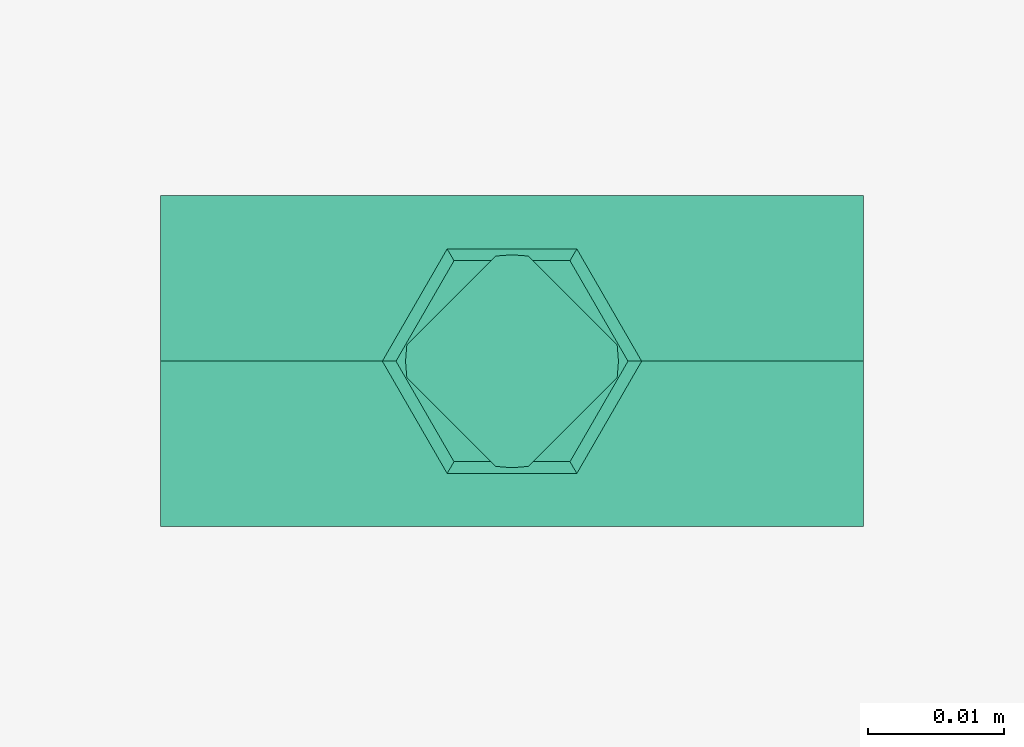
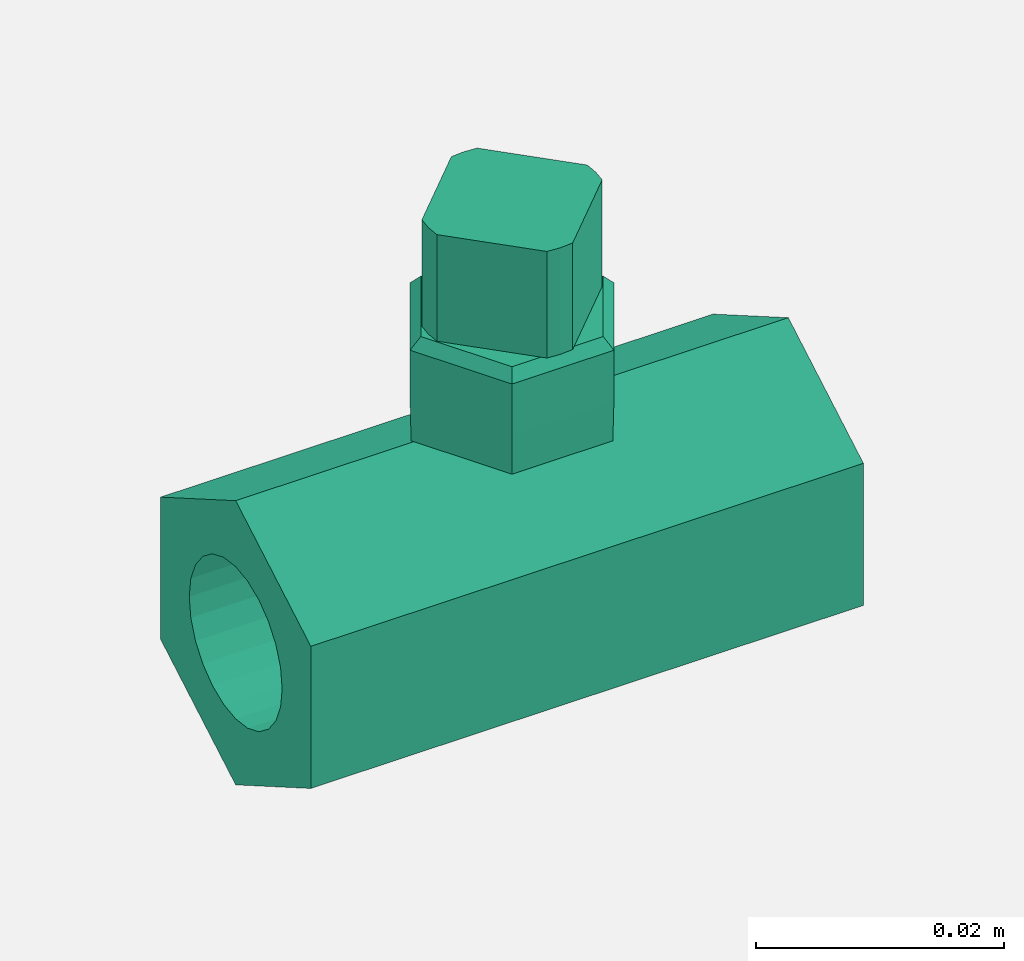
# One storey, part 2 of 2: 1 flow terminal.
"""IFC2X3 building model written with IfcOpenShell, lengths in metres."""

from ifc_helpers import new_model, entity, si_unit, converted_unit, derived_unit, direction, frame, origin, place, context, subcontext, project, spatial, faceted_brep, source, transform, mapped, material, element, save


model = new_model("IFC2X3")

# Units and contexts
model_context = context("Model", 3, precision=1e-05, world=origin(), true_north=direction((6.12303176911189e-17, 1.0)))
body_context = subcontext(model_context, "Body", "Model", "MODEL_VIEW")
ifc_project = project(units=[si_unit("LENGTHUNIT", "METRE"), si_unit("AREAUNIT", "SQUARE_METRE"), si_unit("VOLUMEUNIT", "CUBIC_METRE"), converted_unit("PLANEANGLEUNIT", "DEGREE", entity("IfcRatioMeasure", 0.0174532925199433), si_unit("PLANEANGLEUNIT", "RADIAN"), dimensions=[0, 0, 0, 0, 0, 0, 0]), si_unit("MASSUNIT", "GRAM", prefix="KILO"), derived_unit("MASSDENSITYUNIT", [(si_unit("MASSUNIT", "GRAM", prefix="KILO"), 1), (si_unit("LENGTHUNIT", "METRE"), -3)]), si_unit("TIMEUNIT", "SECOND"), si_unit("FREQUENCYUNIT", "HERTZ"), si_unit("THERMODYNAMICTEMPERATUREUNIT", "DEGREE_CELSIUS"), derived_unit("THERMALTRANSMITTANCEUNIT", [(si_unit("MASSUNIT", "GRAM", prefix="KILO"), 1), (si_unit("THERMODYNAMICTEMPERATUREUNIT", "KELVIN"), -1), (si_unit("TIMEUNIT", "SECOND"), -3)]), derived_unit("VOLUMETRICFLOWRATEUNIT", [(si_unit("LENGTHUNIT", "METRE"), 3), (si_unit("TIMEUNIT", "SECOND"), -1)]), si_unit("ELECTRICCURRENTUNIT", "AMPERE"), si_unit("ELECTRICVOLTAGEUNIT", "VOLT"), si_unit("POWERUNIT", "WATT"), si_unit("FORCEUNIT", "NEWTON", prefix="KILO"), si_unit("ILLUMINANCEUNIT", "LUX"), si_unit("LUMINOUSFLUXUNIT", "LUMEN"), si_unit("LUMINOUSINTENSITYUNIT", "CANDELA"), derived_unit("USERDEFINED", [(si_unit("MASSUNIT", "GRAM", prefix="KILO"), -1), (si_unit("LENGTHUNIT", "METRE"), -2), (si_unit("TIMEUNIT", "SECOND"), 3), (si_unit("LUMINOUSFLUXUNIT", "LUMEN"), 1)]), derived_unit("LINEARVELOCITYUNIT", [(si_unit("LENGTHUNIT", "METRE"), 1), (si_unit("TIMEUNIT", "SECOND"), -1)]), si_unit("PRESSUREUNIT", "PASCAL"), derived_unit("USERDEFINED", [(si_unit("LENGTHUNIT", "METRE"), -2), (si_unit("MASSUNIT", "GRAM", prefix="KILO"), 1), (si_unit("TIMEUNIT", "SECOND"), -2)])], contexts=[model_context])

# Site, building, storey
site_placement = place(None, origin())
site = spatial("IfcSite", under=ifc_project, at=site_placement, CompositionType="ELEMENT")
building_placement = place(site_placement, origin())
building = spatial("IfcBuilding", under=site, at=building_placement, CompositionType="ELEMENT")
storey_placement = place(building_placement, origin())
storey = spatial("IfcBuildingStorey", under=building, at=storey_placement, Name="0 - Piano Terra", CompositionType="ELEMENT", Elevation=0.0)

# Flow terminal
ifc_material = material(Name="di")
shared_shape = source(origin(), body_context, "Body", "Brep", [
    faceted_brep([(0.00120285026843495, 0.00770265547619037, 0.0486326952382922), (0.0, 0.00779596025503844, 0.0486326952382922), (-0.00120285026843501, 0.00770265547619036, 0.0486326952382922), (-0.00770669522115193, 0.00119881052347343, 0.0486326952382922), (-0.0078, -4.03974496152365e-06, 0.0486326952382922), (-0.00770669522115196, -0.0012068900133965, 0.0486326952382922), (-0.00120285026843499, -0.00771073496611347, 0.0486326952382922), (0.0, -0.00780403974496155, 0.0486326952382922), (0.00120285026843493, -0.00771073496611348, 0.0486326952382922), (0.00770669522115189, -0.00120689001339652, 0.0486326952382922), (0.00779999999999997, -4.03974496154639e-06, 0.0486326952382922), (0.00770669522115189, 0.00119881052347343, 0.0486326952382922), (0.0077066952211519, -0.00120689001339647, 0.0381326944485307), (0.00120285026843493, -0.00771073496611348, 0.0381326944485307), (0.0, -0.00780403974496155, 0.0381326944485307), (-0.00120285026843494, -0.00771073496611348, 0.0381326944485307), (-0.00770669522115193, -0.00120689001339648, 0.0381326944485307), (-0.0078, -4.03974496152365e-06, 0.0381326944485307), (-0.00770669522115193, 0.00119881052347338, 0.0381326944485307), (-0.00120285026843501, 0.00770265547619036, 0.0381326944485307), (0.0, 0.00779596025503844, 0.0381326944485307), (0.00120285026843491, 0.00770265547619038, 0.0381326944485307), (0.00770669522115189, 0.00119881052347343, 0.0381326944485307), (0.00779999999999997, -4.03974496154639e-06, 0.0381326944485307)], [[[0, 1, 2, 3, 4, 5, 6, 7, 8, 9, 10, 11]], [[12, 13, 14, 15, 16, 17, 18, 19, 20, 21, 22, 23]], [[3, 2, 19, 18]], [[3, 18, 17, 4]], [[17, 16, 5, 4]], [[6, 5, 16, 15]], [[6, 15, 14, 7]], [[14, 13, 8, 7]], [[9, 8, 13, 12]], [[9, 12, 23, 10]], [[23, 22, 11, 10]], [[0, 11, 22, 21]], [[0, 21, 20, 1]], [[20, 19, 2, 1]]]),
    faceted_brep([(-0.00425000059604643, 0.00736121696455046, 0.0381326944485307), (-0.00850000119209289, 0.0, 0.0381326944485307), (0.0, 0.0, 0.0381326944485307), (0.00425000059604645, 0.00736121696455045, 0.0381326944485307), (-0.00425000059604648, -0.00736121696455044, 0.0381326944485307), (0.0042500005960464, -0.00736121696455048, 0.0381326944485307), (0.00850000119209289, 0.0, 0.0381326944485307), (0.0, 0.0, 0.028175), (-0.00939737323296503, 0.0, 0.0281750000000001), (-0.00469868661648251, 0.00813836394859161, 0.028175), (0.00469868661648249, 0.00813836394859159, 0.028175), (0.00939737323296499, 0.0, 0.028175), (-0.00469868661648256, -0.00813836394859158, 0.028175), (0.00469868661648244, -0.00813836394859162, 0.028175), (0.00475000021234156, 0.00822724170373854, 0.0321326953277006), (0.00950000042468312, 0.0, 0.0321326953277006), (-0.00475000021234156, 0.00822724170373856, 0.0321326953277007), (-0.00950000042468315, 0.0, 0.0321326953277007), (-0.00475000021234161, -0.00822724170373853, 0.0321326953277007), (0.00475000021234151, -0.00822724170373857, 0.0321326953277006), (0.00475000021234155, 0.0082272417037385, 0.0371326961472631), (0.00950000042468308, 0.0, 0.0371326961472631), (-0.00475000021234153, 0.00822724170373852, 0.0371326961472631), (-0.00950000042468309, 0.0, 0.0371326961472631), (-0.00475000021234158, -0.00822724170373849, 0.0371326961472631), (0.00475000021234149, -0.00822724170373853, 0.0371326961472631)], [[[0, 1, 2]], [[2, 3, 0]], [[1, 4, 2]], [[5, 2, 4]], [[2, 5, 6]], [[2, 6, 3]], [[7, 8, 9]], [[9, 10, 7]], [[10, 11, 7]], [[7, 12, 8]], [[11, 13, 7]], [[12, 7, 13]], [[11, 10, 14, 15]], [[10, 9, 16, 14]], [[9, 8, 17, 16]], [[8, 12, 18, 17]], [[12, 13, 19, 18]], [[13, 11, 15, 19]], [[15, 14, 20, 21]], [[14, 16, 22, 20]], [[16, 17, 23, 22]], [[17, 18, 24, 23]], [[18, 19, 25, 24]], [[19, 15, 21, 25]], [[21, 20, 3, 6]], [[20, 22, 0, 3]], [[22, 23, 1, 0]], [[23, 24, 4, 1]], [[24, 25, 5, 4]], [[25, 21, 6, 5]]]),
    faceted_brep([(0.02575, -0.00375000000000001, 0.0204951905283833), (0.02575, 0.0, 0.028), (0.02575, -0.0121243556529821, 0.0210000000000001), (0.02575, -0.00194114283826891, 0.021244443697168), (0.02575, -0.00530330085889911, 0.0193033008588991), (0.02575, 0.0, 0.0215), (0.02575, 0.00194114283826889, 0.021244443697168), (0.02575, 0.00374999999999999, 0.0204951905283833), (0.02575, 0.0121243556529822, 0.0209999999999998), (0.02575, 0.00530330085889909, 0.0193033008588991), (0.02575, 0.00649519052838328, 0.01775), (0.02575, 0.00724444369716801, 0.0159411428382689), (0.02575, 0.0075, 0.014), (0.02575, 0.0121243556529821, 0.00699999999999986), (0.02575, 0.00724444369716802, 0.0120588571617311), (0.02575, 0.0064951905283833, 0.01025), (0.02575, 0.00530330085889913, 0.0086966991411009), (0.02575, 0.00375000000000003, 0.00750480947161671), (0.02575, 0.0, 0.0), (0.02575, 0.00194114283826894, 0.00675555630283198), (0.02575, 0.0, 0.00649999999999998), (0.02575, -0.00194114283826887, 0.00675555630283196), (0.02575, -0.00374999999999997, 0.00750480947161667), (0.02575, -0.0121243556529822, 0.00700000000000008), (0.02575, -0.00530330085889908, 0.00869669914110085), (0.02575, -0.00649519052838327, 0.0102499999999999), (0.02575, -0.007244443697168, 0.012058857161731), (0.02575, -0.0075, 0.014), (0.02575, -0.00724444369716801, 0.0159411428382689), (0.02575, -0.00649519052838329, 0.01775), (-0.02575, -0.00374999999999997, 0.00750480947161667), (-0.02575, 0.0, 0.0), (-0.02575, -0.0121243556529822, 0.00700000000000008), (-0.02575, -0.00194114283826887, 0.00675555630283196), (-0.02575, -0.00530330085889908, 0.00869669914110085), (-0.02575, 0.0, 0.00649999999999998), (-0.02575, 0.00194114283826894, 0.00675555630283198), (-0.02575, 0.00375000000000003, 0.00750480947161671), (-0.02575, 0.0121243556529821, 0.00699999999999986), (-0.02575, 0.00530330085889913, 0.0086966991411009), (-0.02575, 0.0064951905283833, 0.01025), (-0.02575, 0.00724444369716802, 0.0120588571617311), (-0.02575, 0.0075, 0.014), (-0.02575, 0.0121243556529822, 0.0209999999999998), (-0.02575, 0.00724444369716801, 0.0159411428382689), (-0.02575, 0.00649519052838328, 0.01775), (-0.02575, 0.00530330085889909, 0.0193033008588991), (-0.02575, 0.00374999999999999, 0.0204951905283833), (-0.02575, 0.0, 0.028), (-0.02575, 0.00194114283826889, 0.021244443697168), (-0.02575, 0.0, 0.0215), (-0.02575, -0.00194114283826891, 0.021244443697168), (-0.02575, -0.00375000000000001, 0.0204951905283833), (-0.02575, -0.0121243556529821, 0.0210000000000001), (-0.02575, -0.00530330085889911, 0.0193033008588991), (-0.02575, -0.00649519052838329, 0.01775), (-0.02575, -0.00724444369716801, 0.0159411428382689), (-0.02575, -0.0075, 0.0139999999999999), (-0.02575, -0.007244443697168, 0.012058857161731), (-0.02575, -0.00649519052838327, 0.0102499999999999)], [[[0, 1, 2]], [[1, 0, 3]], [[0, 2, 4]], [[5, 1, 3]], [[1, 5, 6]], [[7, 1, 6]], [[1, 7, 8]], [[7, 9, 8]], [[9, 10, 8]], [[10, 11, 8]], [[8, 11, 12]], [[12, 13, 8]], [[12, 14, 13]], [[15, 13, 14]], [[15, 16, 13]], [[17, 13, 16]], [[13, 17, 18]], [[19, 18, 17]], [[18, 19, 20]], [[18, 20, 21]], [[21, 22, 18]], [[18, 22, 23]], [[23, 22, 24]], [[24, 25, 23]], [[25, 26, 23]], [[26, 27, 23]], [[27, 28, 2]], [[2, 23, 27]], [[28, 29, 2]], [[29, 4, 2]], [[30, 31, 32]], [[31, 30, 33]], [[30, 32, 34]], [[35, 31, 33]], [[31, 35, 36]], [[37, 31, 36]], [[31, 37, 38]], [[37, 39, 38]], [[39, 40, 38]], [[40, 41, 38]], [[38, 41, 42]], [[42, 43, 38]], [[42, 44, 43]], [[45, 43, 44]], [[45, 46, 43]], [[47, 43, 46]], [[43, 47, 48]], [[49, 48, 47]], [[48, 49, 50]], [[48, 50, 51]], [[51, 52, 48]], [[48, 52, 53]], [[53, 52, 54]], [[54, 55, 53]], [[55, 56, 53]], [[56, 57, 53]], [[57, 58, 32]], [[32, 53, 57]], [[58, 59, 32]], [[59, 34, 32]], [[23, 2, 53, 32]], [[18, 23, 32, 31]], [[13, 18, 31, 38]], [[8, 13, 38, 43]], [[1, 8, 43, 48]], [[2, 1, 48, 53]], [[12, 42, 41, 14]], [[14, 41, 40, 15]], [[17, 16, 39, 37]], [[39, 16, 15, 40]], [[19, 17, 37, 36]], [[19, 36, 35, 20]], [[20, 35, 33, 21]], [[21, 33, 30, 22]], [[25, 24, 34, 59]], [[34, 24, 22, 30]], [[26, 25, 59, 58]], [[26, 58, 57, 27]], [[27, 57, 56, 28]], [[28, 56, 55, 29]], [[0, 4, 54, 52]], [[54, 4, 29, 55]], [[3, 0, 52, 51]], [[3, 51, 50, 5]], [[5, 50, 49, 6]], [[6, 49, 47, 7]], [[9, 46, 45, 10]], [[7, 47, 46, 9]], [[10, 45, 44, 11]], [[11, 44, 42, 12]]]),
    faceted_brep([(0.00120285026843495, 0.00770265547619037, 0.0486326952382922), (0.0, 0.00779596025503844, 0.0486326952382922), (-0.00120285026843501, 0.00770265547619036, 0.0486326952382922), (-0.00770669522115193, 0.00119881052347343, 0.0486326952382922), (-0.0078, -4.03974496152365e-06, 0.0486326952382922), (-0.00770669522115196, -0.0012068900133965, 0.0486326952382922), (-0.00120285026843499, -0.00771073496611347, 0.0486326952382922), (0.0, -0.00780403974496155, 0.0486326952382922), (0.00120285026843493, -0.00771073496611348, 0.0486326952382922), (0.00770669522115189, -0.00120689001339652, 0.0486326952382922), (0.00779999999999997, -4.03974496154639e-06, 0.0486326952382922), (0.00770669522115189, 0.00119881052347343, 0.0486326952382922), (0.0077066952211519, -0.00120689001339647, 0.0381326944485307), (0.00120285026843493, -0.00771073496611348, 0.0381326944485307), (0.0, -0.00780403974496155, 0.0381326944485307), (-0.00120285026843494, -0.00771073496611348, 0.0381326944485307), (-0.00770669522115193, -0.00120689001339648, 0.0381326944485307), (-0.0078, -4.03974496152365e-06, 0.0381326944485307), (-0.00770669522115193, 0.00119881052347338, 0.0381326944485307), (-0.00120285026843501, 0.00770265547619036, 0.0381326944485307), (0.0, 0.00779596025503844, 0.0381326944485307), (0.00120285026843491, 0.00770265547619038, 0.0381326944485307), (0.00770669522115189, 0.00119881052347343, 0.0381326944485307), (0.00779999999999997, -4.03974496154639e-06, 0.0381326944485307)], [[[0, 1, 2, 3, 4, 5, 6, 7, 8, 9, 10, 11]], [[12, 13, 14, 15, 16, 17, 18, 19, 20, 21, 22, 23]], [[3, 2, 19, 18]], [[3, 18, 17, 4]], [[17, 16, 5, 4]], [[6, 5, 16, 15]], [[6, 15, 14, 7]], [[14, 13, 8, 7]], [[9, 8, 13, 12]], [[9, 12, 23, 10]], [[23, 22, 11, 10]], [[0, 11, 22, 21]], [[0, 21, 20, 1]], [[20, 19, 2, 1]]]),
    faceted_brep([(-0.00425000059604643, 0.00736121696455046, 0.0381326944485307), (-0.00850000119209289, 0.0, 0.0381326944485307), (0.0, 0.0, 0.0381326944485307), (0.00425000059604645, 0.00736121696455045, 0.0381326944485307), (-0.00425000059604648, -0.00736121696455044, 0.0381326944485307), (0.0042500005960464, -0.00736121696455048, 0.0381326944485307), (0.00850000119209289, 0.0, 0.0381326944485307), (0.0, 0.0, 0.028175), (-0.00939737323296503, 0.0, 0.0281750000000001), (-0.00469868661648251, 0.00813836394859161, 0.028175), (0.00469868661648249, 0.00813836394859159, 0.028175), (0.00939737323296499, 0.0, 0.028175), (-0.00469868661648256, -0.00813836394859158, 0.028175), (0.00469868661648244, -0.00813836394859162, 0.028175), (0.00475000021234156, 0.00822724170373854, 0.0321326953277006), (0.00950000042468312, 0.0, 0.0321326953277006), (-0.00475000021234156, 0.00822724170373856, 0.0321326953277007), (-0.00950000042468315, 0.0, 0.0321326953277007), (-0.00475000021234161, -0.00822724170373853, 0.0321326953277007), (0.00475000021234151, -0.00822724170373857, 0.0321326953277006), (0.00475000021234155, 0.0082272417037385, 0.0371326961472631), (0.00950000042468308, 0.0, 0.0371326961472631), (-0.00475000021234153, 0.00822724170373852, 0.0371326961472631), (-0.00950000042468309, 0.0, 0.0371326961472631), (-0.00475000021234158, -0.00822724170373849, 0.0371326961472631), (0.00475000021234149, -0.00822724170373853, 0.0371326961472631)], [[[0, 1, 2]], [[2, 3, 0]], [[1, 4, 2]], [[5, 2, 4]], [[2, 5, 6]], [[2, 6, 3]], [[7, 8, 9]], [[9, 10, 7]], [[10, 11, 7]], [[7, 12, 8]], [[11, 13, 7]], [[12, 7, 13]], [[11, 10, 14, 15]], [[10, 9, 16, 14]], [[9, 8, 17, 16]], [[8, 12, 18, 17]], [[12, 13, 19, 18]], [[13, 11, 15, 19]], [[15, 14, 20, 21]], [[14, 16, 22, 20]], [[16, 17, 23, 22]], [[17, 18, 24, 23]], [[18, 19, 25, 24]], [[19, 15, 21, 25]], [[21, 20, 3, 6]], [[20, 22, 0, 3]], [[22, 23, 1, 0]], [[23, 24, 4, 1]], [[24, 25, 5, 4]], [[25, 21, 6, 5]]]),
    faceted_brep([(0.02575, -0.00375000000000001, 0.0204951905283833), (0.02575, 0.0, 0.028), (0.02575, -0.0121243556529821, 0.0210000000000001), (0.02575, -0.00194114283826891, 0.021244443697168), (0.02575, -0.00530330085889911, 0.0193033008588991), (0.02575, 0.0, 0.0215), (0.02575, 0.00194114283826889, 0.021244443697168), (0.02575, 0.00374999999999999, 0.0204951905283833), (0.02575, 0.0121243556529822, 0.0209999999999998), (0.02575, 0.00530330085889909, 0.0193033008588991), (0.02575, 0.00649519052838328, 0.01775), (0.02575, 0.00724444369716801, 0.0159411428382689), (0.02575, 0.0075, 0.014), (0.02575, 0.0121243556529821, 0.00699999999999986), (0.02575, 0.00724444369716802, 0.0120588571617311), (0.02575, 0.0064951905283833, 0.01025), (0.02575, 0.00530330085889913, 0.0086966991411009), (0.02575, 0.00375000000000003, 0.00750480947161671), (0.02575, 0.0, 0.0), (0.02575, 0.00194114283826894, 0.00675555630283198), (0.02575, 0.0, 0.00649999999999998), (0.02575, -0.00194114283826887, 0.00675555630283196), (0.02575, -0.00374999999999997, 0.00750480947161667), (0.02575, -0.0121243556529822, 0.00700000000000008), (0.02575, -0.00530330085889908, 0.00869669914110085), (0.02575, -0.00649519052838327, 0.0102499999999999), (0.02575, -0.007244443697168, 0.012058857161731), (0.02575, -0.0075, 0.014), (0.02575, -0.00724444369716801, 0.0159411428382689), (0.02575, -0.00649519052838329, 0.01775), (-0.02575, -0.00374999999999997, 0.00750480947161667), (-0.02575, 0.0, 0.0), (-0.02575, -0.0121243556529822, 0.00700000000000008), (-0.02575, -0.00194114283826887, 0.00675555630283196), (-0.02575, -0.00530330085889908, 0.00869669914110085), (-0.02575, 0.0, 0.00649999999999998), (-0.02575, 0.00194114283826894, 0.00675555630283198), (-0.02575, 0.00375000000000003, 0.00750480947161671), (-0.02575, 0.0121243556529821, 0.00699999999999986), (-0.02575, 0.00530330085889913, 0.0086966991411009), (-0.02575, 0.0064951905283833, 0.01025), (-0.02575, 0.00724444369716802, 0.0120588571617311), (-0.02575, 0.0075, 0.014), (-0.02575, 0.0121243556529822, 0.0209999999999998), (-0.02575, 0.00724444369716801, 0.0159411428382689), (-0.02575, 0.00649519052838328, 0.01775), (-0.02575, 0.00530330085889909, 0.0193033008588991), (-0.02575, 0.00374999999999999, 0.0204951905283833), (-0.02575, 0.0, 0.028), (-0.02575, 0.00194114283826889, 0.021244443697168), (-0.02575, 0.0, 0.0215), (-0.02575, -0.00194114283826891, 0.021244443697168), (-0.02575, -0.00375000000000001, 0.0204951905283833), (-0.02575, -0.0121243556529821, 0.0210000000000001), (-0.02575, -0.00530330085889911, 0.0193033008588991), (-0.02575, -0.00649519052838329, 0.01775), (-0.02575, -0.00724444369716801, 0.0159411428382689), (-0.02575, -0.0075, 0.0139999999999999), (-0.02575, -0.007244443697168, 0.012058857161731), (-0.02575, -0.00649519052838327, 0.0102499999999999)], [[[0, 1, 2]], [[1, 0, 3]], [[0, 2, 4]], [[5, 1, 3]], [[1, 5, 6]], [[7, 1, 6]], [[1, 7, 8]], [[7, 9, 8]], [[9, 10, 8]], [[10, 11, 8]], [[8, 11, 12]], [[12, 13, 8]], [[12, 14, 13]], [[15, 13, 14]], [[15, 16, 13]], [[17, 13, 16]], [[13, 17, 18]], [[19, 18, 17]], [[18, 19, 20]], [[18, 20, 21]], [[21, 22, 18]], [[18, 22, 23]], [[23, 22, 24]], [[24, 25, 23]], [[25, 26, 23]], [[26, 27, 23]], [[27, 28, 2]], [[2, 23, 27]], [[28, 29, 2]], [[29, 4, 2]], [[30, 31, 32]], [[31, 30, 33]], [[30, 32, 34]], [[35, 31, 33]], [[31, 35, 36]], [[37, 31, 36]], [[31, 37, 38]], [[37, 39, 38]], [[39, 40, 38]], [[40, 41, 38]], [[38, 41, 42]], [[42, 43, 38]], [[42, 44, 43]], [[45, 43, 44]], [[45, 46, 43]], [[47, 43, 46]], [[43, 47, 48]], [[49, 48, 47]], [[48, 49, 50]], [[48, 50, 51]], [[51, 52, 48]], [[48, 52, 53]], [[53, 52, 54]], [[54, 55, 53]], [[55, 56, 53]], [[56, 57, 53]], [[57, 58, 32]], [[32, 53, 57]], [[58, 59, 32]], [[59, 34, 32]], [[23, 2, 53, 32]], [[18, 23, 32, 31]], [[13, 18, 31, 38]], [[8, 13, 38, 43]], [[1, 8, 43, 48]], [[2, 1, 48, 53]], [[12, 42, 41, 14]], [[14, 41, 40, 15]], [[17, 16, 39, 37]], [[39, 16, 15, 40]], [[19, 17, 37, 36]], [[19, 36, 35, 20]], [[20, 35, 33, 21]], [[21, 33, 30, 22]], [[25, 24, 34, 59]], [[34, 24, 22, 30]], [[26, 25, 59, 58]], [[26, 58, 57, 27]], [[27, 57, 56, 28]], [[28, 56, 55, 29]], [[0, 4, 54, 52]], [[54, 4, 29, 55]], [[3, 0, 52, 51]], [[3, 51, 50, 5]], [[5, 50, 49, 6]], [[6, 49, 47, 7]], [[9, 46, 45, 10]], [[7, 47, 46, 9]], [[10, 45, 44, 11]], [[11, 44, 42, 12]]]),
    faceted_brep([(0.00120285026843495, 0.00770265547619037, 0.0486326952382922), (0.0, 0.00779596025503844, 0.0486326952382922), (-0.00120285026843501, 0.00770265547619036, 0.0486326952382922), (-0.00770669522115193, 0.00119881052347343, 0.0486326952382922), (-0.0078, -4.03974496152365e-06, 0.0486326952382922), (-0.00770669522115196, -0.0012068900133965, 0.0486326952382922), (-0.00120285026843499, -0.00771073496611347, 0.0486326952382922), (0.0, -0.00780403974496155, 0.0486326952382922), (0.00120285026843493, -0.00771073496611348, 0.0486326952382922), (0.00770669522115189, -0.00120689001339652, 0.0486326952382922), (0.00779999999999997, -4.03974496154639e-06, 0.0486326952382922), (0.00770669522115189, 0.00119881052347343, 0.0486326952382922), (0.0077066952211519, -0.00120689001339647, 0.0381326944485307), (0.00120285026843493, -0.00771073496611348, 0.0381326944485307), (0.0, -0.00780403974496155, 0.0381326944485307), (-0.00120285026843494, -0.00771073496611348, 0.0381326944485307), (-0.00770669522115193, -0.00120689001339648, 0.0381326944485307), (-0.0078, -4.03974496152365e-06, 0.0381326944485307), (-0.00770669522115193, 0.00119881052347338, 0.0381326944485307), (-0.00120285026843501, 0.00770265547619036, 0.0381326944485307), (0.0, 0.00779596025503844, 0.0381326944485307), (0.00120285026843491, 0.00770265547619038, 0.0381326944485307), (0.00770669522115189, 0.00119881052347343, 0.0381326944485307), (0.00779999999999997, -4.03974496154639e-06, 0.0381326944485307)], [[[0, 1, 2, 3, 4, 5, 6, 7, 8, 9, 10, 11]], [[12, 13, 14, 15, 16, 17, 18, 19, 20, 21, 22, 23]], [[3, 2, 19, 18]], [[3, 18, 17, 4]], [[17, 16, 5, 4]], [[6, 5, 16, 15]], [[6, 15, 14, 7]], [[14, 13, 8, 7]], [[9, 8, 13, 12]], [[9, 12, 23, 10]], [[23, 22, 11, 10]], [[0, 11, 22, 21]], [[0, 21, 20, 1]], [[20, 19, 2, 1]]]),
    faceted_brep([(-0.00425000059604643, 0.00736121696455046, 0.0381326944485307), (-0.00850000119209289, 0.0, 0.0381326944485307), (0.0, 0.0, 0.0381326944485307), (0.00425000059604645, 0.00736121696455045, 0.0381326944485307), (-0.00425000059604648, -0.00736121696455044, 0.0381326944485307), (0.0042500005960464, -0.00736121696455048, 0.0381326944485307), (0.00850000119209289, 0.0, 0.0381326944485307), (0.0, 0.0, 0.028175), (-0.00939737323296503, 0.0, 0.0281750000000001), (-0.00469868661648251, 0.00813836394859161, 0.028175), (0.00469868661648249, 0.00813836394859159, 0.028175), (0.00939737323296499, 0.0, 0.028175), (-0.00469868661648256, -0.00813836394859158, 0.028175), (0.00469868661648244, -0.00813836394859162, 0.028175), (0.00475000021234156, 0.00822724170373854, 0.0321326953277006), (0.00950000042468312, 0.0, 0.0321326953277006), (-0.00475000021234156, 0.00822724170373856, 0.0321326953277007), (-0.00950000042468315, 0.0, 0.0321326953277007), (-0.00475000021234161, -0.00822724170373853, 0.0321326953277007), (0.00475000021234151, -0.00822724170373857, 0.0321326953277006), (0.00475000021234155, 0.0082272417037385, 0.0371326961472631), (0.00950000042468308, 0.0, 0.0371326961472631), (-0.00475000021234153, 0.00822724170373852, 0.0371326961472631), (-0.00950000042468309, 0.0, 0.0371326961472631), (-0.00475000021234158, -0.00822724170373849, 0.0371326961472631), (0.00475000021234149, -0.00822724170373853, 0.0371326961472631)], [[[0, 1, 2]], [[2, 3, 0]], [[1, 4, 2]], [[5, 2, 4]], [[2, 5, 6]], [[2, 6, 3]], [[7, 8, 9]], [[9, 10, 7]], [[10, 11, 7]], [[7, 12, 8]], [[11, 13, 7]], [[12, 7, 13]], [[11, 10, 14, 15]], [[10, 9, 16, 14]], [[9, 8, 17, 16]], [[8, 12, 18, 17]], [[12, 13, 19, 18]], [[13, 11, 15, 19]], [[15, 14, 20, 21]], [[14, 16, 22, 20]], [[16, 17, 23, 22]], [[17, 18, 24, 23]], [[18, 19, 25, 24]], [[19, 15, 21, 25]], [[21, 20, 3, 6]], [[20, 22, 0, 3]], [[22, 23, 1, 0]], [[23, 24, 4, 1]], [[24, 25, 5, 4]], [[25, 21, 6, 5]]]),
    faceted_brep([(0.02575, -0.00375000000000001, 0.0204951905283833), (0.02575, 0.0, 0.028), (0.02575, -0.0121243556529821, 0.0210000000000001), (0.02575, -0.00194114283826891, 0.021244443697168), (0.02575, -0.00530330085889911, 0.0193033008588991), (0.02575, 0.0, 0.0215), (0.02575, 0.00194114283826889, 0.021244443697168), (0.02575, 0.00374999999999999, 0.0204951905283833), (0.02575, 0.0121243556529822, 0.0209999999999998), (0.02575, 0.00530330085889909, 0.0193033008588991), (0.02575, 0.00649519052838328, 0.01775), (0.02575, 0.00724444369716801, 0.0159411428382689), (0.02575, 0.0075, 0.014), (0.02575, 0.0121243556529821, 0.00699999999999986), (0.02575, 0.00724444369716802, 0.0120588571617311), (0.02575, 0.0064951905283833, 0.01025), (0.02575, 0.00530330085889913, 0.0086966991411009), (0.02575, 0.00375000000000003, 0.00750480947161671), (0.02575, 0.0, 0.0), (0.02575, 0.00194114283826894, 0.00675555630283198), (0.02575, 0.0, 0.00649999999999998), (0.02575, -0.00194114283826887, 0.00675555630283196), (0.02575, -0.00374999999999997, 0.00750480947161667), (0.02575, -0.0121243556529822, 0.00700000000000008), (0.02575, -0.00530330085889908, 0.00869669914110085), (0.02575, -0.00649519052838327, 0.0102499999999999), (0.02575, -0.007244443697168, 0.012058857161731), (0.02575, -0.0075, 0.014), (0.02575, -0.00724444369716801, 0.0159411428382689), (0.02575, -0.00649519052838329, 0.01775), (-0.02575, -0.00374999999999997, 0.00750480947161667), (-0.02575, 0.0, 0.0), (-0.02575, -0.0121243556529822, 0.00700000000000008), (-0.02575, -0.00194114283826887, 0.00675555630283196), (-0.02575, -0.00530330085889908, 0.00869669914110085), (-0.02575, 0.0, 0.00649999999999998), (-0.02575, 0.00194114283826894, 0.00675555630283198), (-0.02575, 0.00375000000000003, 0.00750480947161671), (-0.02575, 0.0121243556529821, 0.00699999999999986), (-0.02575, 0.00530330085889913, 0.0086966991411009), (-0.02575, 0.0064951905283833, 0.01025), (-0.02575, 0.00724444369716802, 0.0120588571617311), (-0.02575, 0.0075, 0.014), (-0.02575, 0.0121243556529822, 0.0209999999999998), (-0.02575, 0.00724444369716801, 0.0159411428382689), (-0.02575, 0.00649519052838328, 0.01775), (-0.02575, 0.00530330085889909, 0.0193033008588991), (-0.02575, 0.00374999999999999, 0.0204951905283833), (-0.02575, 0.0, 0.028), (-0.02575, 0.00194114283826889, 0.021244443697168), (-0.02575, 0.0, 0.0215), (-0.02575, -0.00194114283826891, 0.021244443697168), (-0.02575, -0.00375000000000001, 0.0204951905283833), (-0.02575, -0.0121243556529821, 0.0210000000000001), (-0.02575, -0.00530330085889911, 0.0193033008588991), (-0.02575, -0.00649519052838329, 0.01775), (-0.02575, -0.00724444369716801, 0.0159411428382689), (-0.02575, -0.0075, 0.0139999999999999), (-0.02575, -0.007244443697168, 0.012058857161731), (-0.02575, -0.00649519052838327, 0.0102499999999999)], [[[0, 1, 2]], [[1, 0, 3]], [[0, 2, 4]], [[5, 1, 3]], [[1, 5, 6]], [[7, 1, 6]], [[1, 7, 8]], [[7, 9, 8]], [[9, 10, 8]], [[10, 11, 8]], [[8, 11, 12]], [[12, 13, 8]], [[12, 14, 13]], [[15, 13, 14]], [[15, 16, 13]], [[17, 13, 16]], [[13, 17, 18]], [[19, 18, 17]], [[18, 19, 20]], [[18, 20, 21]], [[21, 22, 18]], [[18, 22, 23]], [[23, 22, 24]], [[24, 25, 23]], [[25, 26, 23]], [[26, 27, 23]], [[27, 28, 2]], [[2, 23, 27]], [[28, 29, 2]], [[29, 4, 2]], [[30, 31, 32]], [[31, 30, 33]], [[30, 32, 34]], [[35, 31, 33]], [[31, 35, 36]], [[37, 31, 36]], [[31, 37, 38]], [[37, 39, 38]], [[39, 40, 38]], [[40, 41, 38]], [[38, 41, 42]], [[42, 43, 38]], [[42, 44, 43]], [[45, 43, 44]], [[45, 46, 43]], [[47, 43, 46]], [[43, 47, 48]], [[49, 48, 47]], [[48, 49, 50]], [[48, 50, 51]], [[51, 52, 48]], [[48, 52, 53]], [[53, 52, 54]], [[54, 55, 53]], [[55, 56, 53]], [[56, 57, 53]], [[57, 58, 32]], [[32, 53, 57]], [[58, 59, 32]], [[59, 34, 32]], [[23, 2, 53, 32]], [[18, 23, 32, 31]], [[13, 18, 31, 38]], [[8, 13, 38, 43]], [[1, 8, 43, 48]], [[2, 1, 48, 53]], [[12, 42, 41, 14]], [[14, 41, 40, 15]], [[17, 16, 39, 37]], [[39, 16, 15, 40]], [[19, 17, 37, 36]], [[19, 36, 35, 20]], [[20, 35, 33, 21]], [[21, 33, 30, 22]], [[25, 24, 34, 59]], [[34, 24, 22, 30]], [[26, 25, 59, 58]], [[26, 58, 57, 27]], [[27, 57, 56, 28]], [[28, 56, 55, 29]], [[0, 4, 54, 52]], [[54, 4, 29, 55]], [[3, 0, 52, 51]], [[3, 51, 50, 5]], [[5, 50, 49, 6]], [[6, 49, 47, 7]], [[9, 46, 45, 10]], [[7, 47, 46, 9]], [[10, 45, 44, 11]], [[11, 44, 42, 12]]]),
])
flow_terminal_placement = place(storey_placement, frame((3.279751614672, 2.33452196488701, 0.0)))
element("IfcFlowTerminal", 1, at=flow_terminal_placement, inside=storey, material=ifc_material, context=body_context, shape_type="MappedRepresentation", body=[
    mapped(shared_shape, transform((0.0, 0.0, 0.0), scale=1.0)),
])

save(model, "model.ifc")
